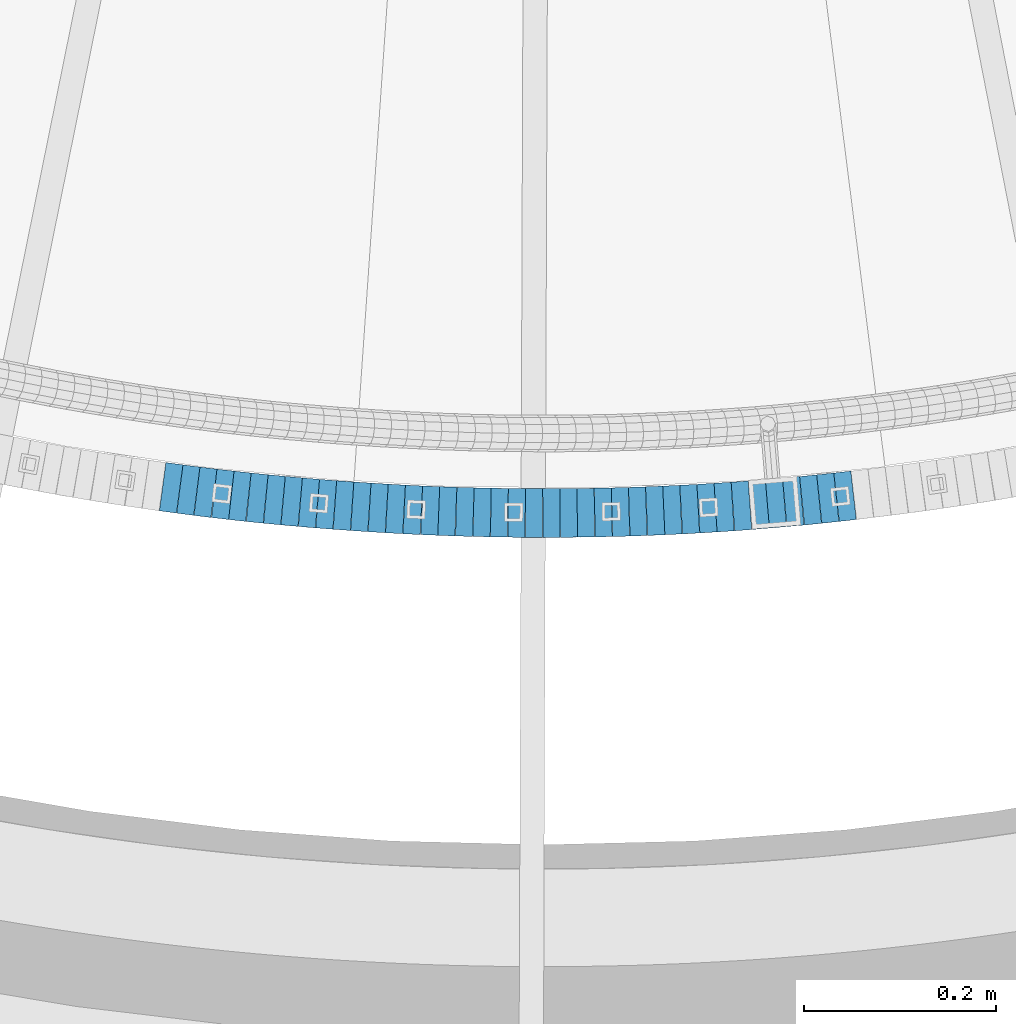
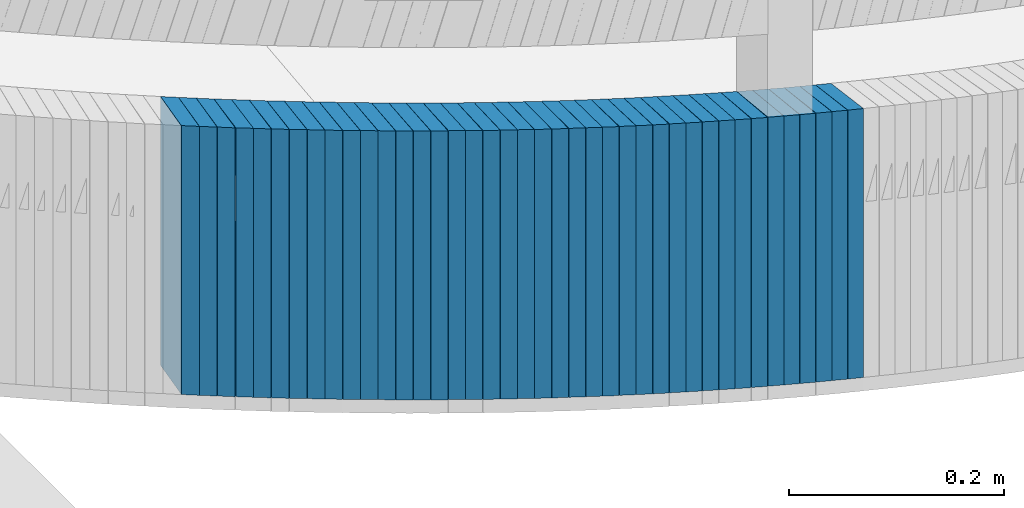
# One storey, part 877 of 975: 40 plates.
"""IFC2X3 building model written with IfcOpenShell, lengths in millimetres."""

import ifcopenshell
import ifcopenshell.guid

model = None  # the IFC model being written
_history = None  # IfcOwnerHistory: only IFC2X3 demands one
_inside = {}  # id of a spatial element -> (the spatial element, [elements in it])
_under = {}  # id of a project, library or spatial element -> (it, [spatial elements below it])
_declared = {}  # id of a project -> (the project, [libraries it declares])
_typed = {}  # id of a type object -> (the type object, [elements of that type])
_made_of = {}  # id of a material, layer set ... -> (it, [elements and type objects made of it])


def new_model(schema):
    """Start an empty IFC model of exactly this schema.

    Asked for "IFC4X3", IfcOpenShell would pick the latest addendum, in which some entities
    have other attributes; the version numbers below select the first issue.
    IFC2X3 requires an IfcOwnerHistory on every rooted entity: one is made here for all.
    """
    global model, _history
    if schema == "IFC4X3":
        model = ifcopenshell.file(schema_version=(4, 3, 0, 0))
    else:
        model = ifcopenshell.file(schema=schema)
    _inside.clear()
    _under.clear()
    _declared.clear()
    _typed.clear()
    _made_of.clear()
    _history = None
    if model.schema == "IFC2X3":
        org = make("IfcOrganization", Name="unknown")
        user = make(
            "IfcPersonAndOrganization",
            ThePerson=make("IfcPerson", FamilyName="unknown"),
            TheOrganization=org,
        )
        app = make(
            "IfcApplication",
            ApplicationDeveloper=org,
            Version="unknown",
            ApplicationFullName="unknown",
            ApplicationIdentifier="unknown",
        )
        _history = make(
            "IfcOwnerHistory",
            OwningUser=user,
            OwningApplication=app,
            ChangeAction="ADDED",
            CreationDate=0,
        )
    return model


def make(cls, **values):
    """One entity of the class cls with the attributes given. An attribute that is None is left unset."""
    return model.create_entity(
        cls, **{name: value for name, value in values.items() if value is not None}
    )


def rooted(cls, **values):
    """An entity with a GlobalId (a new one), such as an element, a storey or a relation."""
    return make(cls, GlobalId=ifcopenshell.guid.new(), OwnerHistory=_history, **values)


def si_unit(unit_type, name, prefix=None):
    """IfcSIUnit, for example si_unit("LENGTHUNIT", "METRE", prefix="MILLI")."""
    return make("IfcSIUnit", UnitType=unit_type, Prefix=prefix, Name=name)


def assignment(units):
    """IfcUnitAssignment: the units of a project."""
    return None if units is None else make("IfcUnitAssignment", Units=units)


def point(xyz):
    """IfcCartesianPoint."""
    return None if xyz is None else make("IfcCartesianPoint", Coordinates=xyz)


def direction(xyz):
    """IfcDirection."""
    return None if xyz is None else make("IfcDirection", DirectionRatios=xyz)


def frame(location, z_axis=None, x_axis=None):
    """IfcAxis2Placement3D, a coordinate frame: its origin and axes. An axis left out is left unset."""
    return make(
        "IfcAxis2Placement3D",
        Location=point(location),
        Axis=direction(z_axis),
        RefDirection=direction(x_axis),
    )


def origin_with_axes():
    """The frame at (0, 0, 0) with the z axis (0, 0, 1) and the x axis (1, 0, 0) written out."""
    return frame((0.0, 0.0, 0.0), z_axis=(0.0, 0.0, 1.0), x_axis=(1.0, 0.0, 0.0))


def place(relative_to, where):
    """IfcLocalPlacement: puts the frame where relative to a parent placement (None: the world)."""
    return make(
        "IfcLocalPlacement", PlacementRelTo=relative_to, RelativePlacement=where
    )


def context(
    kind, dimensions, precision=None, world=None, true_north=None, identifier=None
):
    """IfcGeometricRepresentationContext, for example the 3D "Model" context."""
    return make(
        "IfcGeometricRepresentationContext",
        ContextIdentifier=identifier,
        ContextType=kind,
        CoordinateSpaceDimension=dimensions,
        Precision=precision,
        WorldCoordinateSystem=world,
        TrueNorth=true_north,
    )


def subcontext(parent, identifier, kind, view, scale=None):
    """IfcGeometricRepresentationSubContext, for example "Body" below "Model"."""
    return make(
        "IfcGeometricRepresentationSubContext",
        ContextIdentifier=identifier,
        ContextType=kind,
        ParentContext=parent,
        TargetScale=scale,
        TargetView=view,
    )


def project(units=None, contexts=None):
    """IfcProject with its units and contexts."""
    return rooted(
        "IfcProject",
        Name="project",
        RepresentationContexts=contexts,
        UnitsInContext=assignment(units),
    )


def spatial(cls, under=None, at=None, **own):
    """A site, building, storey or space (cls), placed at a placement, below another one or the project."""
    s = rooted(cls, ObjectPlacement=at, **own)
    if under is not None:
        _under.setdefault(under.id(), (under, []))[1].append(s)
    return s


def faces_of(points, faces, orient=None, outer=None):
    """IfcFace entities. A face is a list of loops; a loop is a list of indices into points, from 0.

    orient and outer hold one flag for each loop. By default every Orientation is true, the
    first loop of a face is its IfcFaceOuterBound and the others are IfcFaceBound.
    """
    made = []
    for i, loops in enumerate(faces):
        bounds = []
        for j, loop in enumerate(loops):
            is_outer = j == 0 if outer is None else outer[i][j]
            bounds.append(
                make(
                    "IfcFaceOuterBound" if is_outer else "IfcFaceBound",
                    Bound=make("IfcPolyLoop", Polygon=[points[k] for k in loop]),
                    Orientation=True if orient is None else orient[i][j],
                )
            )
        made.append(make("IfcFace", Bounds=bounds))
    return made


def faceted_brep(points, faces, orient=None, outer=None, voids=None):
    """IfcFacetedBrep: a solid bounded by flat faces; with voids (closed shells), ...WithVoids."""
    shared = [point(p) for p in points]
    hull = make("IfcClosedShell", CfsFaces=faces_of(shared, faces, orient, outer))
    if voids is None:
        return make("IfcFacetedBrep", Outer=hull)
    return make(
        "IfcFacetedBrepWithVoids",
        Outer=hull,
        Voids=[
            make(cls, CfsFaces=faces_of(shared, fs, o, b)) for cls, fs, o, b in voids
        ],
    )


def shape(context_of_items, identifier, shape_type, items):
    """IfcShapeRepresentation: the items that make up one representation, for example the "Body"."""
    return make(
        "IfcShapeRepresentation",
        ContextOfItems=context_of_items,
        RepresentationIdentifier=identifier,
        RepresentationType=shape_type,
        Items=items,
    )


def material(Name=None, Category=None):
    """IfcMaterial."""
    return make("IfcMaterial", Name=Name, Category=Category)


def made_of(thing, what):
    """Note that an element or type object is made of a material, layer set ...; save() writes the relation."""
    if what is not None:
        _made_of.setdefault(what.id(), (what, []))[1].append(thing)
    return thing


def type_object(cls, material=None, **own):
    """A type object (cls), such as IfcWallType, which elements share."""
    return made_of(rooted(cls, **own), material)


def element(
    cls,
    number,
    at=None,
    inside=None,
    cuts=None,
    type_object=None,
    material=None,
    context=None,
    identifier="Body",
    shape_type=None,
    held_by="IfcProductDefinitionShape",
    body=None,
    shapes=None,
    **own,
):
    """One element of the class cls, such as IfcWall. Its Tag is "e" and its number.

    at: its placement. inside: the storey or other place that contains it. cuts: it is an
    opening in that element (IfcRelVoidsElement). A single representation is given by context,
    identifier, shape_type and body (its items); several are given by shapes. held_by: the class
    of the entity that holds the representations. save() writes the other relations.
    """
    e = rooted(cls, Tag="e%d" % number, ObjectPlacement=at, **own)
    if body is not None:
        shapes = [shape(context, identifier, shape_type, body)]
    if shapes is not None:
        e.Representation = make(held_by, Representations=shapes)
    if inside is not None:
        _inside.setdefault(inside.id(), (inside, []))[1].append(e)
    if cuts is not None:
        rooted(
            "IfcRelVoidsElement", RelatingBuildingElement=cuts, RelatedOpeningElement=e
        )
    if type_object is not None:
        _typed.setdefault(type_object.id(), (type_object, []))[1].append(e)
    return made_of(e, material)


def aggregate(whole, parts):
    """IfcRelAggregates: a whole, such as a stair, and the parts it consists of."""
    return rooted("IfcRelAggregates", RelatingObject=whole, RelatedObjects=parts)


def save(model, path):
    """Write the relations noted so far, then the file.

    IfcRelAggregates (storeys below a building ...), IfcRelContainedInSpatialStructure (elements
    in a storey), IfcRelDefinesByType, IfcRelAssociatesMaterial and IfcRelDeclares: one each for
    every whole, place, type object, material and project.
    """
    for whole, parts in _under.values():
        aggregate(whole, parts)
    for where, things in _inside.values():
        rooted(
            "IfcRelContainedInSpatialStructure",
            RelatedElements=things,
            RelatingStructure=where,
        )
    for kind, things in _typed.values():
        rooted("IfcRelDefinesByType", RelatedObjects=things, RelatingType=kind)
    for what, things in _made_of.values():
        rooted("IfcRelAssociatesMaterial", RelatedObjects=things, RelatingMaterial=what)
    for by, libraries in _declared.values():
        rooted("IfcRelDeclares", RelatingContext=by, RelatedDefinitions=libraries)
    model.write(path)


model = new_model("IFC2X3")

# Units and contexts
model_context = context("Model", 3, precision=1e-05, world=origin_with_axes())
body_context = subcontext(model_context, "Body", "Model", "MODEL_VIEW")
ifc_project = project(units=[si_unit("LENGTHUNIT", "METRE", prefix="MILLI"), si_unit("AREAUNIT", "SQUARE_METRE"), si_unit("VOLUMEUNIT", "CUBIC_METRE"), si_unit("MASSUNIT", "GRAM", prefix="KILO"), si_unit("TIMEUNIT", "SECOND"), si_unit("PLANEANGLEUNIT", "RADIAN"), si_unit("SOLIDANGLEUNIT", "STERADIAN"), si_unit("THERMODYNAMICTEMPERATUREUNIT", "DEGREE_CELSIUS"), si_unit("LUMINOUSINTENSITYUNIT", "LUMEN")], contexts=[model_context])

# Site, building, storey
site_placement = place(None, origin_with_axes())
site = spatial("IfcSite", under=ifc_project, at=site_placement, CompositionType="ELEMENT")
building_placement = place(site_placement, origin_with_axes())
building = spatial("IfcBuilding", under=site, at=building_placement, Name="Undefined", CompositionType="ELEMENT")
storey_placement = place(building_placement, origin_with_axes())
storey = spatial("IfcBuildingStorey", under=building, at=storey_placement, Name="Undefined", CompositionType="ELEMENT", Elevation=0.0)

# Plates
ifc_material = material(Name="STEEL/A36")
plate_type = type_object("IfcPlateType", PredefinedType="NOTDEFINED")
plate_1_placement = place(storey_placement, frame((34356.0974371153, 557.930019480635, 3183.1875000677), z_axis=(-0.991032326071817, 0.133622336009683, 0.0), x_axis=(0.0, 0.0, 1.0)))
element("IfcPlate", 1, at=plate_1_placement, inside=storey, type_object=plate_type, material=ifc_material, Name="WALL", context=body_context, shape_type="Brep", body=[
    faceted_brep([(0.0, -25.3999999999724, -1.81898940354586e-11), (5.69999980926514, -25.400000000016, 17.9627399444762), (5.69999980926514, 25.3999999999869, 17.9627399444762), (0.0, 25.3999999999869, 1.45519152283669e-11), (310.5, -25.400000000016, 17.9627399444762), (310.5, 25.3999999999869, 17.9627399444762), (304.799987792969, -25.3999999999724, -1.81898940354586e-11), (304.799987792969, 25.3999999999869, 1.45519152283669e-11)], [[[0, 1, 2, 3]], [[1, 4, 5, 2]], [[4, 6, 7, 5]], [[6, 0, 3, 7]], [[5, 7, 3, 2]], [[6, 4, 1, 0]]]),
])
plate_2_placement = place(storey_placement, frame((34373.918397017, 555.614005997245, 3177.4875000677), z_axis=(-0.991662778167147, 0.12886013502172, 0.0), x_axis=(0.0, 0.0, 1.0)))
element("IfcPlate", 2, at=plate_2_placement, inside=storey, type_object=plate_type, material=ifc_material, Name="WALL", context=body_context, shape_type="Brep", body=[
    faceted_brep([(0.0, -25.3999999999724, -1.81898940354586e-11), (5.69999980926514, -25.4000000000196, 17.8538513183848), (5.69999980926514, 25.4000000000415, 17.8538513183157), (0.0, 25.3999999999869, 1.45519152283669e-11), (310.5, -25.4000000000196, 17.8538513183848), (310.5, 25.4000000000415, 17.8538513183157), (304.799987792969, -25.3999999999724, -1.81898940354586e-11), (304.799987792969, 25.3999999999869, 1.45519152283669e-11)], [[[0, 1, 2, 3]], [[1, 4, 5, 2]], [[4, 6, 7, 5]], [[6, 0, 3, 7]], [[5, 7, 3, 2]], [[6, 4, 1, 0]]]),
])
plate_3_placement = place(storey_placement, frame((34391.7584899881, 553.396197709423, 3171.6875000677), z_axis=(-0.992363891859749, 0.123344663982567, 0.0), x_axis=(0.0, 0.0, 1.0)))
element("IfcPlate", 3, at=plate_3_placement, inside=storey, type_object=plate_type, material=ifc_material, Name="WALL", context=body_context, shape_type="Brep", body=[
    faceted_brep([(0.0, -25.3999999999724, -1.81898940354586e-11), (5.80000019073486, -25.3999999999614, 17.8392829894583), (5.80000019073486, 25.3999999999578, 17.8392829895529), (0.0, 25.3999999999869, 1.45519152283669e-11), (310.600006103516, -25.3999999999614, 17.8392829894583), (310.600006103516, 25.3999999999578, 17.8392829895529), (304.799987792969, -25.3999999999724, -1.81898940354586e-11), (304.799987792969, 25.3999999999869, 1.45519152283669e-11)], [[[0, 1, 2, 3]], [[1, 4, 5, 2]], [[4, 6, 7, 5]], [[6, 0, 3, 7]], [[5, 7, 3, 2]], [[6, 4, 1, 0]]]),
])
for number, where, z_axis, x_axis, name in (
    (4, (34409.8553580408, 551.361071534118, 3165.9875000677), (-0.993746812135698, 0.111656945015247, 0.0), (0.0, 0.0, 1.0), "WALL"),
    (5, (34427.6553580317, 549.361071533807, 3160.2875000677), (-0.993746812135698, 0.111656945015247, 0.0), (0.0, 0.0, 1.0), "WALL"),
):
    element("IfcPlate", number, at=place(storey_placement, frame(where, z_axis=z_axis, x_axis=x_axis)), inside=storey, type_object=plate_type, material=ifc_material, Name=name, context=body_context, shape_type="Brep", body=[
        faceted_brep([(0.0, -25.3999999999724, -1.81898940354586e-11), (5.69999980926514, -25.4000000000633, 17.9075393677485), (5.69999980926514, 25.3999999999905, 17.9075393676903), (0.0, 25.3999999999869, 1.45519152283669e-11), (310.5, -25.4000000000633, 17.9075393677485), (310.5, 25.3999999999905, 17.9075393676903), (304.799987792969, -25.3999999999724, -1.81898940354586e-11), (304.799987792969, 25.3999999999869, 1.45519152283669e-11)], [[[0, 1, 2, 3]], [[1, 4, 5, 2]], [[4, 6, 7, 5]], [[6, 0, 3, 7]], [[5, 7, 3, 2]], [[6, 4, 1, 0]]]),
    ])
plate_4_placement = place(storey_placement, frame((34445.6216476487, 547.532572094641, 3154.4875000677), z_axis=(-0.994868837297448, 0.101173102030249, 0.0), x_axis=(0.0, 0.0, 1.0)))
element("IfcPlate", 6, at=plate_4_placement, inside=storey, type_object=plate_type, material=ifc_material, Name="WALL", context=body_context, shape_type="Brep", body=[
    faceted_brep([(0.0, -25.3999999999724, -1.81898940354586e-11), (5.80000019073486, -25.4000000000124, 17.7912902832286), (5.80000019073486, 25.3999999999833, 17.7912902832286), (0.0, 25.3999999999869, 1.45519152283669e-11), (310.600006103516, -25.4000000000124, 17.7912902832286), (310.600006103516, 25.3999999999833, 17.7912902832286), (304.799987792969, -25.3999999999724, -1.81898940354586e-11), (304.799987792969, 25.3999999999869, 1.45519152283669e-11)], [[[0, 1, 2, 3]], [[1, 4, 5, 2]], [[4, 6, 7, 5]], [[6, 0, 3, 7]], [[5, 7, 3, 2]], [[6, 4, 1, 0]]]),
])
plate_5_placement = place(storey_placement, frame((34463.6899599584, 545.816021542835, 3148.7875000677), z_axis=(-0.995520433839131, 0.0945466329847219, 0.0), x_axis=(0.0, 0.0, 1.0)))
element("IfcPlate", 7, at=plate_5_placement, inside=storey, type_object=plate_type, material=ifc_material, Name="WALL", context=body_context, shape_type="Brep", body=[
    faceted_brep([(0.0, -25.3999999999724, -1.81898940354586e-11), (5.69999980926514, -25.4000000000233, 17.9805450439708), (5.69999980926514, 25.4000000000124, 17.9805450439344), (0.0, 25.3999999999869, 1.45519152283669e-11), (310.5, -25.4000000000233, 17.9805450439708), (310.5, 25.4000000000124, 17.9805450439344), (304.799987792969, -25.3999999999724, -1.81898940354586e-11), (304.799987792969, 25.3999999999869, 1.45519152283669e-11)], [[[0, 1, 2, 3]], [[1, 4, 5, 2]], [[4, 6, 7, 5]], [[6, 0, 3, 7]], [[5, 7, 3, 2]], [[6, 4, 1, 0]]]),
])
plate_6_placement = place(storey_placement, frame((34481.6174665191, 544.20423620698, 3142.9875000677), z_axis=(-0.995984423457655, 0.0895266900411377, 0.0), x_axis=(0.0, 0.0, 1.0)))
element("IfcPlate", 8, at=plate_6_placement, inside=storey, type_object=plate_type, material=ifc_material, Name="WALL", context=body_context, shape_type="Brep", body=[
    faceted_brep([(0.0, -25.3999999999724, -1.81898940354586e-11), (5.80000019073486, -25.3999999999705, 17.873443603421), (5.80000019073486, 25.3999999999924, 17.8734436035338), (0.0, 25.3999999999869, 1.45519152283669e-11), (310.600006103516, -25.3999999999705, 17.873443603421), (310.600006103516, 25.3999999999924, 17.8734436035338), (304.799987792969, -25.3999999999724, -1.81898940354586e-11), (304.799987792969, 25.3999999999869, 1.45519152283669e-11)], [[[0, 1, 2, 3]], [[1, 4, 5, 2]], [[4, 6, 7, 5]], [[6, 0, 3, 7]], [[5, 7, 3, 2]], [[6, 4, 1, 0]]]),
])
plate_7_placement = place(storey_placement, frame((34499.5585548421, 542.691950523311, 3137.2875000677), z_axis=(-0.996468111805164, 0.0839720319835808, 0.0), x_axis=(0.0, 0.0, 1.0)))
element("IfcPlate", 9, at=plate_7_placement, inside=storey, type_object=plate_type, material=ifc_material, Name="WALL", context=body_context, shape_type="Brep", body=[
    faceted_brep([(0.0, -25.3999999999724, -1.81898940354586e-11), (5.69999980926514, -25.4000000000378, 17.8639297485788), (5.69999980926514, 25.3999999999833, 17.8639297485533), (0.0, 25.3999999999869, 1.45519152283669e-11), (310.5, -25.4000000000378, 17.8639297485788), (310.5, 25.3999999999833, 17.8639297485533), (304.799987792969, -25.3999999999724, -1.81898940354586e-11), (304.799987792969, 25.3999999999869, 1.45519152283669e-11)], [[[0, 1, 2, 3]], [[1, 4, 5, 2]], [[4, 6, 7, 5]], [[6, 0, 3, 7]], [[5, 7, 3, 2]], [[6, 4, 1, 0]]]),
])
plate_8_placement = place(storey_placement, frame((34517.6109006936, 541.279573911327, 3131.5875000677), z_axis=(-0.996955380018721, 0.0779741640014643, 0.0), x_axis=(0.0, 0.0, 1.0)))
element("IfcPlate", 10, at=plate_8_placement, inside=storey, type_object=plate_type, material=ifc_material, Name="WALL", context=body_context, shape_type="Brep", body=[
    faceted_brep([(0.0, -25.3999999999724, -1.81898940354586e-11), (5.69999980926514, -25.4000000000342, 17.9493732452938), (5.69999980926514, 25.4000000000415, 17.9493732451738), (0.0, 25.3999999999869, 1.45519152283669e-11), (310.5, -25.4000000000342, 17.9493732452938), (310.5, 25.4000000000415, 17.9493732451738), (304.799987792969, -25.3999999999724, -1.81898940354586e-11), (304.799987792969, 25.3999999999869, 1.45519152283669e-11)], [[[0, 1, 2, 3]], [[1, 4, 5, 2]], [[4, 6, 7, 5]], [[6, 0, 3, 7]], [[5, 7, 3, 2]], [[6, 4, 1, 0]]]),
])
plate_9_placement = place(storey_placement, frame((34535.651597477, 539.96896278567, 3125.7875000677), z_axis=(-0.99737314091598, 0.0724349209938983, 0.0), x_axis=(0.0, 0.0, 1.0)))
element("IfcPlate", 11, at=plate_9_placement, inside=storey, type_object=plate_type, material=ifc_material, Name="WALL", context=body_context, shape_type="Brep", body=[
    faceted_brep([(0.0, -25.3999999999724, -1.81898940354586e-11), (5.80000019073486, -25.399999999976, 17.9493732452247), (5.80000019073486, 25.4000000000051, 17.9493732452393), (0.0, 25.3999999999869, 1.45519152283669e-11), (310.600006103516, -25.399999999976, 17.9493732452247), (310.600006103516, 25.4000000000051, 17.9493732452393), (304.799987792969, -25.3999999999724, -1.81898940354586e-11), (304.799987792969, 25.3999999999869, 1.45519152283669e-11)], [[[0, 1, 2, 3]], [[1, 4, 5, 2]], [[4, 6, 7, 5]], [[6, 0, 3, 7]], [[5, 7, 3, 2]], [[6, 4, 1, 0]]]),
])
plate_10_placement = place(storey_placement, frame((34553.6924647135, 538.759125765041, 3119.9875000677), z_axis=(-0.997760425198301, 0.066888967013294, 0.0), x_axis=(0.0, 0.0, 1.0)))
element("IfcPlate", 12, at=plate_10_placement, inside=storey, type_object=plate_type, material=ifc_material, Name="WALL", context=body_context, shape_type="Brep", body=[
    faceted_brep([(0.0, -25.3999999999724, -1.81898940354586e-11), (5.80000019073486, -25.3999999999614, 17.9424076079595), (5.80000019073486, 25.3999999999978, 17.9424076080322), (0.0, 25.3999999999869, 1.45519152283669e-11), (310.600006103516, -25.3999999999614, 17.9424076079595), (310.600006103516, 25.3999999999978, 17.9424076080322), (304.799987792969, -25.3999999999724, -1.81898940354586e-11), (304.799987792969, 25.3999999999869, 1.45519152283669e-11)], [[[0, 1, 2, 3]], [[1, 4, 5, 2]], [[4, 6, 7, 5]], [[6, 0, 3, 7]], [[5, 7, 3, 2]], [[6, 4, 1, 0]]]),
])
for number, where, z_axis, x_axis, name in (
    (13, (34571.733489591, 537.650065579857, 3114.2875000677), (-0.998117125443553, 0.0613368070272576, 0.0), (0.0, 0.0, 1.0), "WALL"),
    (14, (34589.7746592574, 536.641784741657, 3108.5875000677), (-0.998443142690188, 0.0557789459826923, 0.0), (0.0, 0.0, 1.0), "WALL"),
):
    element("IfcPlate", number, at=place(storey_placement, frame(where, z_axis=z_axis, x_axis=x_axis)), inside=storey, type_object=plate_type, material=ifc_material, Name=name, context=body_context, shape_type="Brep", body=[
        faceted_brep([(0.0, -25.3999999999724, -1.81898940354586e-11), (5.69999980926514, -25.3999999999896, 17.9334888457815), (5.69999980926514, 25.3999999999869, 17.9334888458907), (0.0, 25.3999999999869, 1.45519152283669e-11), (310.5, -25.3999999999896, 17.9334888457815), (310.5, 25.3999999999869, 17.9334888458907), (304.799987792969, -25.3999999999724, -1.81898940354586e-11), (304.799987792969, 25.3999999999869, 1.45519152283669e-11)], [[[0, 1, 2, 3]], [[1, 4, 5, 2]], [[4, 6, 7, 5]], [[6, 0, 3, 7]], [[5, 7, 3, 2]], [[6, 4, 1, 0]]]),
    ])
plate_11_placement = place(storey_placement, frame((34607.8159607309, 535.734285560524, 3102.7875000677), z_axis=(-0.998738386059441, 0.0502158960029888, 0.0), x_axis=(0.0, 0.0, 1.0)))
element("IfcPlate", 15, at=plate_11_placement, inside=storey, type_object=plate_type, material=ifc_material, Name="WALL", context=body_context, shape_type="Brep", body=[
    faceted_brep([(0.0, -25.3999999999724, -1.81898940354586e-11), (5.80000019073486, -25.4000000000233, 17.9178676605334), (5.80000019073486, 25.3999999999942, 17.9178676605297), (0.0, 25.3999999999869, 1.45519152283669e-11), (310.600006103516, -25.4000000000233, 17.9178676605334), (310.600006103516, 25.3999999999942, 17.9178676605297), (304.799987792969, -25.3999999999724, -1.81898940354586e-11), (304.799987792969, 25.3999999999869, 1.45519152283669e-11)], [[[0, 1, 2, 3]], [[1, 4, 5, 2]], [[4, 6, 7, 5]], [[6, 0, 3, 7]], [[5, 7, 3, 2]], [[6, 4, 1, 0]]]),
])
plate_12_placement = place(storey_placement, frame((34625.893339581, 535.021858643954, 3097.0875000677), z_axis=(-0.999227634784355, 0.0392954689915193, 0.0), x_axis=(0.0, 0.0, 1.0)))
element("IfcPlate", 16, at=plate_12_placement, inside=storey, type_object=plate_type, material=ifc_material, Name="WALL", context=body_context, shape_type="Brep", body=[
    faceted_brep([(0.0, -25.3999999999724, -1.81898940354586e-11), (5.69999980926514, -25.4000000000306, 17.8058986664291), (5.69999980926514, 25.4000000000415, 17.80589866632), (0.0, 25.3999999999869, 1.45519152283669e-11), (310.5, -25.4000000000306, 17.8058986664291), (310.5, 25.4000000000415, 17.80589866632), (304.799987792969, -25.3999999999724, -1.81898940354586e-11), (304.799987792969, 25.3999999999869, 1.45519152283669e-11)], [[[0, 1, 2, 3]], [[1, 4, 5, 2]], [[4, 6, 7, 5]], [[6, 0, 3, 7]], [[5, 7, 3, 2]], [[6, 4, 1, 0]]]),
])
plate_13_placement = place(storey_placement, frame((34643.7989070725, 534.321640310722, 3091.2875000677), z_axis=(-0.99923623061666, 0.0390762769850089, 0.0), x_axis=(0.0, 0.0, 1.0)))
element("IfcPlate", 17, at=plate_13_placement, inside=storey, type_object=plate_type, material=ifc_material, Name="WALL", context=body_context, shape_type="Brep", body=[
    faceted_brep([(0.0, -25.3999999999724, -1.81898940354586e-11), (5.80000019073486, -25.3999999999905, 17.9067020416114), (5.80000019073486, 25.399999999976, 17.9067020416369), (0.0, 25.3999999999869, 1.45519152283669e-11), (310.600006103516, -25.3999999999905, 17.9067020416114), (310.600006103516, 25.399999999976, 17.9067020416369), (304.799987792969, -25.3999999999724, -1.81898940354586e-11), (304.799987792969, 25.3999999999869, 1.45519152283669e-11)], [[[0, 1, 2, 3]], [[1, 4, 5, 2]], [[4, 6, 7, 5]], [[6, 0, 3, 7]], [[5, 7, 3, 2]], [[6, 4, 1, 0]]]),
])
plate_14_placement = place(storey_placement, frame((34661.9822239284, 533.812143952922, 3085.5875000677), z_axis=(-0.999610102993625, 0.0279220699998219, 0.0), x_axis=(0.0, 0.0, 1.0)))
element("IfcPlate", 18, at=plate_14_placement, inside=storey, type_object=plate_type, material=ifc_material, Name="WALL", context=body_context, shape_type="Brep", body=[
    faceted_brep([(0.0, -25.3999999999724, -1.81898940354586e-11), (5.69999980926514, -25.4000000000633, 17.9075393677485), (5.69999980926514, 25.3999999999905, 17.9075393676903), (0.0, 25.3999999999869, 1.45519152283669e-11), (310.5, -25.4000000000633, 17.9075393677485), (310.5, 25.3999999999905, 17.9075393676903), (304.799987792969, -25.3999999999724, -1.81898940354586e-11), (304.799987792969, 25.3999999999869, 1.45519152283669e-11)], [[[0, 1, 2, 3]], [[1, 4, 5, 2]], [[4, 6, 7, 5]], [[6, 0, 3, 7]], [[5, 7, 3, 2]], [[6, 4, 1, 0]]]),
])
plate_15_placement = place(storey_placement, frame((34680.0239884271, 533.408580070057, 3079.8875000677), z_axis=(-0.999750413381817, 0.0223407910085322, 0.0), x_axis=(0.0, 0.0, 1.0)))
element("IfcPlate", 19, at=plate_15_placement, inside=storey, type_object=plate_type, material=ifc_material, Name="WALL", context=body_context, shape_type="Brep", body=[
    faceted_brep([(0.0, -25.3999999999724, -1.81898940354586e-11), (5.69999980926514, -25.3999999999978, 17.9011173248218), (5.69999980926514, 25.4000000000087, 17.9011173248182), (0.0, 25.3999999999869, 1.45519152283669e-11), (310.5, -25.3999999999978, 17.9011173248218), (310.5, 25.4000000000087, 17.9011173248182), (304.799987792969, -25.3999999999724, -1.81898940354586e-11), (304.799987792969, 25.3999999999869, 1.45519152283669e-11)], [[[0, 1, 2, 3]], [[1, 4, 5, 2]], [[4, 6, 7, 5]], [[6, 0, 3, 7]], [[5, 7, 3, 2]], [[6, 4, 1, 0]]]),
])
plate_16_placement = place(storey_placement, frame((34697.9634154324, 533.10584730081, 3074.0875000677), z_axis=(-0.999858002735129, 0.0168515389955359, 0.0), x_axis=(0.0, 0.0, 1.0)))
element("IfcPlate", 20, at=plate_16_placement, inside=storey, type_object=plate_type, material=ifc_material, Name="WALL", context=body_context, shape_type="Brep", body=[
    faceted_brep([(0.0, -25.3999999999724, -1.81898940354586e-11), (5.80000019073486, -25.4000000000124, 17.8002815246691), (5.80000019073486, 25.4000000000051, 17.8002815246546), (0.0, 25.3999999999869, 1.45519152283669e-11), (310.600006103516, -25.4000000000124, 17.8002815246691), (310.600006103516, 25.4000000000051, 17.8002815246546), (304.799987792969, -25.3999999999724, -1.81898940354586e-11), (304.799987792969, 25.3999999999869, 1.45519152283669e-11)], [[[0, 1, 2, 3]], [[1, 4, 5, 2]], [[4, 6, 7, 5]], [[6, 0, 3, 7]], [[5, 7, 3, 2]], [[6, 4, 1, 0]]]),
])
for number, where, z_axis, x_axis, name in (
    (21, (34716.0076633593, 532.903825890819, 3068.3875000677), (-0.999937585819375, 0.0111724869979819, 0.0), (0.0, 0.0, 1.0), "WALL"),
    (22, (34734.049547293, 532.802636928969, 3062.6875000677), (-0.999984395359179, 0.00558650500200657, 0.0), (0.0, 0.0, 1.0), "WALL"),
):
    element("IfcPlate", number, at=place(storey_placement, frame(where, z_axis=z_axis, x_axis=x_axis)), inside=storey, type_object=plate_type, material=ifc_material, Name=name, context=body_context, shape_type="Brep", body=[
        faceted_brep([(0.0, -25.3999999999724, -1.81898940354586e-11), (5.69999980926514, -25.3999999999978, 17.9011173248218), (5.69999980926514, 25.4000000000087, 17.9011173248182), (0.0, 25.3999999999869, 1.45519152283669e-11), (310.5, -25.3999999999978, 17.9011173248218), (310.5, 25.4000000000087, 17.9011173248182), (304.799987792969, -25.3999999999724, -1.81898940354586e-11), (304.799987792969, 25.3999999999869, 1.45519152283669e-11)], [[[0, 1, 2, 3]], [[1, 4, 5, 2]], [[4, 6, 7, 5]], [[6, 0, 3, 7]], [[5, 7, 3, 2]], [[6, 4, 1, 0]]]),
    ])
plate_17_placement = place(storey_placement, frame((34752.1341389029, 532.902641395533, 3056.8875000677), z_axis=(-0.999984219537095, -0.00561788899739941, 0.0), x_axis=(0.0, 0.0, 1.0)))
element("IfcPlate", 23, at=plate_17_placement, inside=storey, type_object=plate_type, material=ifc_material, Name="WALL", context=body_context, shape_type="Brep", body=[
    faceted_brep([(0.0, -25.3999999999724, -1.81898940354586e-11), (5.80000019073486, -25.4000000000124, 17.8002815246691), (5.80000019073486, 25.4000000000051, 17.8002815246546), (0.0, 25.3999999999869, 1.45519152283669e-11), (310.600006103516, -25.4000000000124, 17.8002815246691), (310.600006103516, 25.4000000000051, 17.8002815246546), (304.799987792969, -25.3999999999724, -1.81898940354586e-11), (304.799987792969, 25.3999999999869, 1.45519152283669e-11)], [[[0, 1, 2, 3]], [[1, 4, 5, 2]], [[4, 6, 7, 5]], [[6, 0, 3, 7]], [[5, 7, 3, 2]], [[6, 4, 1, 0]]]),
])
for number, where, z_axis, x_axis, name in (
    (24, (34770.1752256995, 533.103825892408, 3051.1875000677), (-0.999937585819375, -0.0111724869979819, 0.0), (0.0, 0.0, 1.0), "WALL"),
    (25, (34788.0752257068, 533.303825892846, 3045.4875000677), (-0.999937585819375, -0.0111724869979819, 0.0), (0.0, 0.0, 1.0), "WALL"),
):
    element("IfcPlate", number, at=place(storey_placement, frame(where, z_axis=z_axis, x_axis=x_axis)), inside=storey, type_object=plate_type, material=ifc_material, Name=name, context=body_context, shape_type="Brep", body=[
        faceted_brep([(0.0, -25.3999999999724, -1.81898940354586e-11), (5.69999980926514, -25.3999999999978, 17.9011173248218), (5.69999980926514, 25.4000000000087, 17.9011173248182), (0.0, 25.3999999999869, 1.45519152283669e-11), (310.5, -25.3999999999978, 17.9011173248218), (310.5, 25.4000000000087, 17.9011173248182), (304.799987792969, -25.3999999999724, -1.81898940354586e-11), (304.799987792969, 25.3999999999869, 1.45519152283669e-11)], [[[0, 1, 2, 3]], [[1, 4, 5, 2]], [[4, 6, 7, 5]], [[6, 0, 3, 7]], [[5, 7, 3, 2]], [[6, 4, 1, 0]]]),
    ])
plate_18_placement = place(storey_placement, frame((34806.162086981, 533.708651476667, 3039.7875000677), z_axis=(-0.999747602222632, -0.0224662380050029, 0.0), x_axis=(0.0, 0.0, 1.0)))
element("IfcPlate", 26, at=plate_18_placement, inside=storey, type_object=plate_type, material=ifc_material, Name="WALL", context=body_context, shape_type="Brep", body=[
    faceted_brep([(0.0, -25.3999999999724, -1.81898940354586e-11), (5.69999980926514, -25.4000000000196, 17.8002815246764), (5.69999980926514, 25.4000000000015, 17.8002815246618), (0.0, 25.3999999999869, 1.45519152283669e-11), (310.5, -25.4000000000196, 17.8002815246764), (310.5, 25.4000000000015, 17.8002815246618), (304.799987792969, -25.3999999999724, -1.81898940354586e-11), (304.799987792969, 25.3999999999869, 1.45519152283669e-11)], [[[0, 1, 2, 3]], [[1, 4, 5, 2]], [[4, 6, 7, 5]], [[6, 0, 3, 7]], [[5, 7, 3, 2]], [[6, 4, 1, 0]]]),
])
plate_19_placement = place(storey_placement, frame((34824.2006651076, 534.212143957114, 3033.9875000677), z_axis=(-0.999610102993625, -0.027922069999822, 0.0), x_axis=(0.0, 0.0, 1.0)))
element("IfcPlate", 27, at=plate_19_placement, inside=storey, type_object=plate_type, material=ifc_material, Name="WALL", context=body_context, shape_type="Brep", body=[
    faceted_brep([(0.0, -25.3999999999724, -1.81898940354586e-11), (5.80000019073486, -25.3999999999905, 17.9067020416114), (5.80000019073486, 25.399999999976, 17.9067020416369), (0.0, 25.3999999999869, 1.45519152283669e-11), (310.600006103516, -25.3999999999905, 17.9067020416114), (310.600006103516, 25.399999999976, 17.9067020416369), (304.799987792969, -25.3999999999724, -1.81898940354586e-11), (304.799987792969, 25.3999999999869, 1.45519152283669e-11)], [[[0, 1, 2, 3]], [[1, 4, 5, 2]], [[4, 6, 7, 5]], [[6, 0, 3, 7]], [[5, 7, 3, 2]], [[6, 4, 1, 0]]]),
])
plate_20_placement = place(storey_placement, frame((34842.1471383169, 534.816658285396, 3028.2875000677), z_axis=(-0.999432373568723, -0.0336887319854625, 0.0), x_axis=(0.0, 0.0, 1.0)))
element("IfcPlate", 28, at=plate_20_placement, inside=storey, type_object=plate_type, material=ifc_material, Name="WALL", context=body_context, shape_type="Brep", body=[
    faceted_brep([(0.0, -25.3999999999724, -1.81898940354586e-11), (5.69999980926514, -25.4000000000306, 17.8058986664291), (5.69999980926514, 25.4000000000415, 17.80589866632), (0.0, 25.3999999999869, 1.45519152283669e-11), (310.5, -25.4000000000306, 17.8058986664291), (310.5, 25.4000000000415, 17.80589866632), (304.799987792969, -25.3999999999724, -1.81898940354586e-11), (304.799987792969, 25.3999999999869, 1.45519152283669e-11)], [[[0, 1, 2, 3]], [[1, 4, 5, 2]], [[4, 6, 7, 5]], [[6, 0, 3, 7]], [[5, 7, 3, 2]], [[6, 4, 1, 0]]]),
])
plate_21_placement = place(storey_placement, frame((34860.3255080195, 535.627570133923, 3022.5875000677), z_axis=(-0.999002773271358, -0.0446481690121278, 0.0), x_axis=(0.0, 0.0, 1.0)))
element("IfcPlate", 29, at=plate_21_placement, inside=storey, type_object=plate_type, material=ifc_material, Name="WALL", context=body_context, shape_type="Brep", body=[
    faceted_brep([(0.0, -25.3999999999724, -1.81898940354586e-11), (5.69999980926514, -25.3999999999724, 17.9212169646999), (5.69999980926514, 25.3999999999651, 17.9212169647544), (0.0, 25.3999999999869, 1.45519152283669e-11), (310.5, -25.3999999999724, 17.9212169646999), (310.5, 25.3999999999651, 17.9212169647544), (304.799987792969, -25.3999999999724, -1.81898940354586e-11), (304.799987792969, 25.3999999999869, 1.45519152283669e-11)], [[[0, 1, 2, 3]], [[1, 4, 5, 2]], [[4, 6, 7, 5]], [[6, 0, 3, 7]], [[5, 7, 3, 2]], [[6, 4, 1, 0]]]),
])
plate_22_placement = place(storey_placement, frame((34878.1318663594, 536.427855103212, 3016.8875000677), z_axis=(-0.998991554001901, -0.0448984970000855, 0.0), x_axis=(0.0, 0.0, 1.0)))
element("IfcPlate", 30, at=plate_22_placement, inside=storey, type_object=plate_type, material=ifc_material, Name="WALL", context=body_context, shape_type="Brep", body=[
    faceted_brep([(0.0, -25.3999999999724, -1.81898940354586e-11), (5.69999980926514, -25.3999999999432, 17.8213348388126), (5.69999980926514, 25.3999999999905, 17.8213348388708), (0.0, 25.3999999999869, 1.45519152283669e-11), (310.5, -25.3999999999432, 17.8213348388126), (310.5, 25.3999999999905, 17.8213348388708), (304.799987792969, -25.3999999999724, -1.81898940354586e-11), (304.799987792969, 25.3999999999869, 1.45519152283669e-11)], [[[0, 1, 2, 3]], [[1, 4, 5, 2]], [[4, 6, 7, 5]], [[6, 0, 3, 7]], [[5, 7, 3, 2]], [[6, 4, 1, 0]]]),
])
plate_23_placement = place(storey_placement, frame((34896.2161642718, 537.442229263819, 3011.0875000677), z_axis=(-0.99842564215979, -0.0560913280089769, 0.0), x_axis=(0.0, 0.0, 1.0)))
element("IfcPlate", 31, at=plate_23_placement, inside=storey, type_object=plate_type, material=ifc_material, Name="WALL", context=body_context, shape_type="Brep", body=[
    faceted_brep([(0.0, -25.3999999999724, -1.81898940354586e-11), (5.80000019073486, -25.3999999999796, 17.8280677795228), (5.80000019073486, 25.4000000000196, 17.8280677795265), (0.0, 25.3999999999869, 1.45519152283669e-11), (310.600006103516, -25.3999999999796, 17.8280677795228), (310.600006103516, 25.4000000000196, 17.8280677795265), (304.799987792969, -25.3999999999724, -1.81898940354586e-11), (304.799987792969, 25.3999999999869, 1.45519152283669e-11)], [[[0, 1, 2, 3]], [[1, 4, 5, 2]], [[4, 6, 7, 5]], [[6, 0, 3, 7]], [[5, 7, 3, 2]], [[6, 4, 1, 0]]]),
])
plate_24_placement = place(storey_placement, frame((34914.2493994448, 538.55006558909, 3005.3875000677), z_axis=(-0.998117125443553, -0.0613368070272576, 0.0), x_axis=(0.0, 0.0, 1.0)))
element("IfcPlate", 32, at=plate_24_placement, inside=storey, type_object=plate_type, material=ifc_material, Name="WALL", context=body_context, shape_type="Brep", body=[
    faceted_brep([(0.0, -25.3999999999724, -1.81898940354586e-11), (5.69999980926514, -25.3999999999896, 17.9334888457815), (5.69999980926514, 25.3999999999869, 17.9334888458907), (0.0, 25.3999999999869, 1.45519152283669e-11), (310.5, -25.3999999999896, 17.9334888457815), (310.5, 25.3999999999869, 17.9334888458907), (304.799987792969, -25.3999999999724, -1.81898940354586e-11), (304.799987792969, 25.3999999999869, 1.45519152283669e-11)], [[[0, 1, 2, 3]], [[1, 4, 5, 2]], [[4, 6, 7, 5]], [[6, 0, 3, 7]], [[5, 7, 3, 2]], [[6, 4, 1, 0]]]),
])
plate_25_placement = place(storey_placement, frame((34932.0581187884, 539.650602919895, 2999.6875000677), z_axis=(-0.998095970709494, -0.0616800879820471, 0.0), x_axis=(0.0, 0.0, 1.0)))
element("IfcPlate", 33, at=plate_25_placement, inside=storey, type_object=plate_type, material=ifc_material, Name="WALL", context=body_context, shape_type="Brep", body=[
    faceted_brep([(0.0, -25.3999999999724, -1.81898940354586e-11), (5.69999980926514, -25.3999999999724, 17.833955764745), (5.69999980926514, 25.3999999999905, 17.8339557647923), (0.0, 25.3999999999869, 1.45519152283669e-11), (310.5, -25.3999999999724, 17.833955764745), (310.5, 25.3999999999905, 17.8339557647923), (304.799987792969, -25.3999999999724, -1.81898940354586e-11), (304.799987792969, 25.3999999999869, 1.45519152283669e-11)], [[[0, 1, 2, 3]], [[1, 4, 5, 2]], [[4, 6, 7, 5]], [[6, 0, 3, 7]], [[5, 7, 3, 2]], [[6, 4, 1, 0]]]),
])
plate_26_placement = place(storey_placement, frame((34950.1415730814, 540.96971159832, 2993.8875000677), z_axis=(-0.99734366054768, -0.0728397059669653, 0.0), x_axis=(0.0, 0.0, 1.0)))
element("IfcPlate", 34, at=plate_26_placement, inside=storey, type_object=plate_type, material=ifc_material, Name="WALL", context=body_context, shape_type="Brep", body=[
    faceted_brep([(0.0, -25.3999999999724, -1.81898940354586e-11), (5.80000019073486, -25.4000000000306, 17.853010177645), (5.80000019073486, 25.3999999999578, 17.8530101776596), (0.0, 25.3999999999869, 1.45519152283669e-11), (310.600006103516, -25.4000000000306, 17.853010177645), (310.600006103516, 25.3999999999578, 17.8530101776596), (304.799987792969, -25.3999999999724, -1.81898940354586e-11), (304.799987792969, 25.3999999999869, 1.45519152283669e-11)], [[[0, 1, 2, 3]], [[1, 4, 5, 2]], [[4, 6, 7, 5]], [[6, 0, 3, 7]], [[5, 7, 3, 2]], [[6, 4, 1, 0]]]),
])
plate_27_placement = place(storey_placement, frame((34968.2243341791, 542.491950536428, 2988.1875000677), z_axis=(-0.996468111805164, -0.0839720319835808, 0.0), x_axis=(0.0, 0.0, 1.0)))
element("IfcPlate", 35, at=plate_27_placement, inside=storey, type_object=plate_type, material=ifc_material, Name="WALL", context=body_context, shape_type="Brep", body=[
    faceted_brep([(0.0, -25.3999999999724, -1.81898940354586e-11), (5.69999980926514, -25.4000000000378, 17.8639297485788), (5.69999980926514, 25.3999999999833, 17.8639297485533), (0.0, 25.3999999999869, 1.45519152283669e-11), (310.5, -25.4000000000378, 17.8639297485788), (310.5, 25.3999999999833, 17.8639297485533), (304.799987792969, -25.3999999999724, -1.81898940354586e-11), (304.799987792969, 25.3999999999869, 1.45519152283669e-11)], [[[0, 1, 2, 3]], [[1, 4, 5, 2]], [[4, 6, 7, 5]], [[6, 0, 3, 7]], [[5, 7, 3, 2]], [[6, 4, 1, 0]]]),
])
plate_28_placement = place(storey_placement, frame((34986.1125019286, 543.990956221567, 2982.4875000677), z_axis=(-0.99650725807471, -0.083506195006261, 0.0), x_axis=(0.0, 0.0, 1.0)))
element("IfcPlate", 36, at=plate_28_placement, inside=storey, type_object=plate_type, material=ifc_material, Name="WALL", context=body_context, shape_type="Brep", body=[
    faceted_brep([(0.0, -25.3999999999724, -1.81898940354586e-11), (5.69999980926514, -25.400000000016, 17.9627399444762), (5.69999980926514, 25.3999999999869, 17.9627399444762), (0.0, 25.3999999999869, 1.45519152283669e-11), (310.5, -25.400000000016, 17.9627399444762), (310.5, 25.3999999999869, 17.9627399444762), (304.799987792969, -25.3999999999724, -1.81898940354586e-11), (304.799987792969, 25.3999999999869, 1.45519152283669e-11)], [[[0, 1, 2, 3]], [[1, 4, 5, 2]], [[4, 6, 7, 5]], [[6, 0, 3, 7]], [[5, 7, 3, 2]], [[6, 4, 1, 0]]]),
])
plate_29_placement = place(storey_placement, frame((35004.0654225078, 545.604236221361, 2976.6875000677), z_axis=(-0.995984423457655, -0.0895266900411377, 0.0), x_axis=(0.0, 0.0, 1.0)))
element("IfcPlate", 37, at=plate_29_placement, inside=storey, type_object=plate_type, material=ifc_material, Name="WALL", context=body_context, shape_type="Brep", body=[
    faceted_brep([(0.0, -25.3999999999724, -1.81898940354586e-11), (5.80000019073486, -25.3999999999705, 17.873443603421), (5.80000019073486, 25.3999999999924, 17.8734436035338), (0.0, 25.3999999999869, 1.45519152283669e-11), (310.600006103516, -25.3999999999705, 17.873443603421), (310.600006103516, 25.3999999999924, 17.8734436035338), (304.799987792969, -25.3999999999724, -1.81898940354586e-11), (304.799987792969, 25.3999999999869, 1.45519152283669e-11)], [[[0, 1, 2, 3]], [[1, 4, 5, 2]], [[4, 6, 7, 5]], [[6, 0, 3, 7]], [[5, 7, 3, 2]], [[6, 4, 1, 0]]]),
])
plate_30_placement = place(storey_placement, frame((35022.1469508661, 547.431122918675, 2970.9875000677), z_axis=(-0.994925892068904, -0.100610483006968, 0.0), x_axis=(0.0, 0.0, 1.0)))
element("IfcPlate", 38, at=plate_30_placement, inside=storey, type_object=plate_type, material=ifc_material, Name="WALL", context=body_context, shape_type="Brep", body=[
    faceted_brep([(0.0, -25.3999999999724, -1.81898940354586e-11), (5.69999980926514, -25.3999999999614, 17.8921775817616), (5.69999980926514, 25.400000000016, 17.8921775817726), (0.0, 25.3999999999869, 1.45519152283669e-11), (310.5, -25.3999999999614, 17.8921775817616), (310.5, 25.400000000016, 17.8921775817726), (304.799987792969, -25.3999999999724, -1.81898940354586e-11), (304.799987792969, 25.3999999999869, 1.45519152283669e-11)], [[[0, 1, 2, 3]], [[1, 4, 5, 2]], [[4, 6, 7, 5]], [[6, 0, 3, 7]], [[5, 7, 3, 2]], [[6, 4, 1, 0]]]),
])
plate_31_placement = place(storey_placement, frame((35040.0873656981, 549.345716481832, 2965.1875000677), z_axis=(-0.994351342364744, -0.106138626038933, 0.0), x_axis=(0.0, 0.0, 1.0)))
element("IfcPlate", 39, at=plate_31_placement, inside=storey, type_object=plate_type, material=ifc_material, Name="WALL", context=body_context, shape_type="Brep", body=[
    faceted_brep([(0.0, -25.3999999999724, -1.81898940354586e-11), (5.80000019073486, -25.399999999936, 17.9011173247382), (5.80000019073486, 25.3999999999578, 17.9011173248837), (0.0, 25.3999999999869, 1.45519152283669e-11), (310.600006103516, -25.399999999936, 17.9011173247382), (310.600006103516, 25.3999999999578, 17.9011173248837), (304.799987792969, -25.3999999999724, -1.81898940354586e-11), (304.799987792969, 25.3999999999869, 1.45519152283669e-11)], [[[0, 1, 2, 3]], [[1, 4, 5, 2]], [[4, 6, 7, 5]], [[6, 0, 3, 7]], [[5, 7, 3, 2]], [[6, 4, 1, 0]]]),
])
plate_32_placement = place(storey_placement, frame((35058.0275310079, 551.3610715496, 2959.4875000677), z_axis=(-0.993746812135698, -0.111656945015247, 0.0), x_axis=(0.0, 0.0, 1.0)))
element("IfcPlate", 40, at=plate_32_placement, inside=storey, type_object=plate_type, material=ifc_material, Name="WALL", context=body_context, shape_type="Brep", body=[
    faceted_brep([(0.0, -25.3999999999724, -1.81898940354586e-11), (5.69999980926514, -25.4000000000633, 17.9075393677485), (5.69999980926514, 25.3999999999905, 17.9075393676903), (0.0, 25.3999999999869, 1.45519152283669e-11), (310.5, -25.4000000000633, 17.9075393677485), (310.5, 25.3999999999905, 17.9075393676903), (304.799987792969, -25.3999999999724, -1.81898940354586e-11), (304.799987792969, 25.3999999999869, 1.45519152283669e-11)], [[[0, 1, 2, 3]], [[1, 4, 5, 2]], [[4, 6, 7, 5]], [[6, 0, 3, 7]], [[5, 7, 3, 2]], [[6, 4, 1, 0]]]),
])

save(model, "model.ifc")
